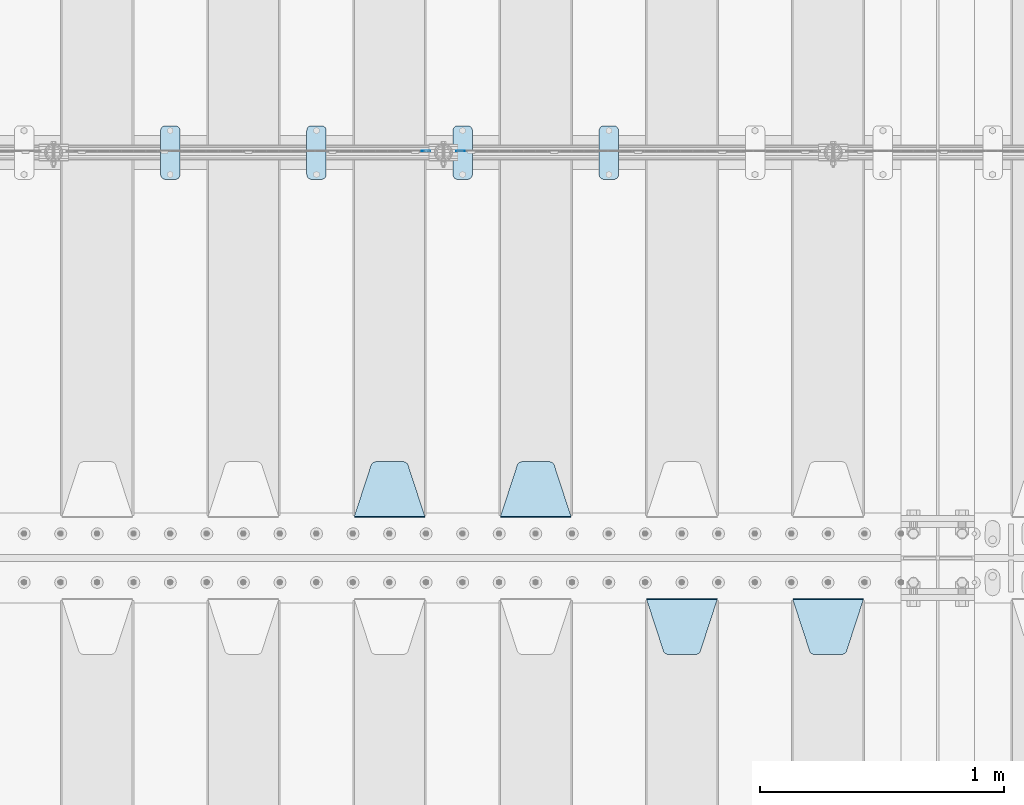
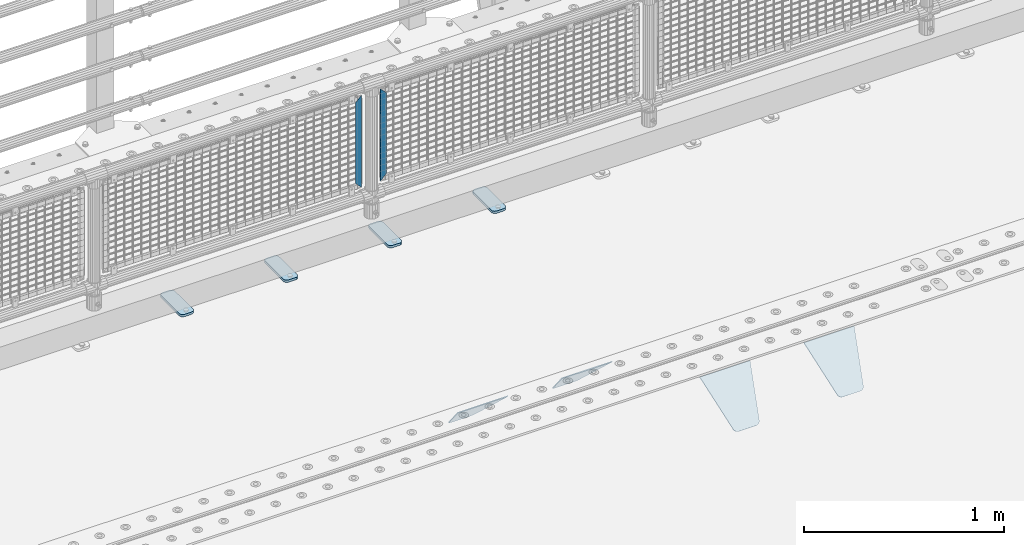
# One storey, part 226 of 257: 10 plates.
"""IFC2X3 building model written with IfcOpenShell, lengths in millimetres."""

from ifc_helpers import new_model, si_unit, frame, origin_with_axes, place, context, subcontext, project, spatial, faceted_brep, material, type_object, element, save


model = new_model("IFC2X3")

# Units and contexts
model_context = context("Model", 3, precision=1e-05, world=origin_with_axes())
body_context = subcontext(model_context, "Body", "Model", "MODEL_VIEW")
ifc_project = project(units=[si_unit("LENGTHUNIT", "METRE", prefix="MILLI"), si_unit("AREAUNIT", "SQUARE_METRE"), si_unit("VOLUMEUNIT", "CUBIC_METRE"), si_unit("MASSUNIT", "GRAM", prefix="KILO"), si_unit("TIMEUNIT", "SECOND"), si_unit("PLANEANGLEUNIT", "RADIAN"), si_unit("SOLIDANGLEUNIT", "STERADIAN"), si_unit("THERMODYNAMICTEMPERATUREUNIT", "DEGREE_CELSIUS"), si_unit("LUMINOUSINTENSITYUNIT", "LUMEN")], contexts=[model_context])

# Site, building, storey
site_placement = place(None, origin_with_axes())
site = spatial("IfcSite", under=ifc_project, at=site_placement, CompositionType="ELEMENT")
building_placement = place(site_placement, origin_with_axes())
building = spatial("IfcBuilding", under=site, at=building_placement, Name="Standard", CompositionType="ELEMENT")
storey_placement = place(building_placement, origin_with_axes())
storey = spatial("IfcBuildingStorey", under=building, at=storey_placement, Name="Undefined", CompositionType="ELEMENT", Elevation=0.0)

# Plates
ifc_material_1 = material(Name="STEEL/S355J2")
plate_type_1 = type_object("IfcPlateType", PredefinedType="NOTDEFINED")
plate_1_placement = place(storey_placement, frame((53310.0, 10774.5, 21.0199999999977), z_axis=(1.0, 0.0, 0.0), x_axis=(0.0, -1.0, 0.0)))
element("IfcPlate", 1, at=plate_1_placement, inside=storey, type_object=plate_type_1, material=ifc_material_1, context=body_context, shape_type="Brep", body=[
    faceted_brep([(0.0, -7.0, 20.0), (0.0, -7.0, 60.0), (0.0, 7.0, 60.0), (0.0, 7.0, 20.0), (0.384294391935327, -7.0, 63.9018064403208), (0.384294391935327, 7.0, 63.9018064403208), (1.52240934977453, -7.0, 67.6536686473046), (1.52240934977453, 7.0, 67.6536686473046), (3.37060775394821, -7.0, 71.1114046603907), (3.37060775394821, 7.0, 71.1114046603907), (5.85786437626848, -7.0, 74.1421356237333), (5.85786437626848, 7.0, 74.1421356237333), (8.88859533960749, -7.0, 76.6293922460536), (8.88859533960749, 7.0, 76.6293922460536), (12.3463313526991, -7.0, 78.4775906502255), (12.3463313526991, 7.0, 78.4775906502255), (16.0981935596774, -7.0, 79.6157056080629), (16.0981935596774, 7.0, 79.6157056080629), (20.0, -7.0, 80.0), (20.0, 7.0, 80.0), (200.0, -7.0, 80.0), (200.0, 7.0, 80.0), (203.901806440323, -7.0, 79.6157056080629), (203.901806440323, 7.0, 79.6157056080629), (207.653668647301, -7.0, 78.4775906502255), (207.653668647301, 7.0, 78.4775906502255), (211.111404660393, -7.0, 76.6293922460536), (211.111404660393, 7.0, 76.6293922460536), (214.142135623732, -7.0, 74.1421356237333), (214.142135623732, 7.0, 74.1421356237333), (216.629392246052, -7.0, 71.1114046603907), (216.629392246052, 7.0, 71.1114046603907), (218.477590650225, -7.0, 67.6536686473046), (218.477590650225, 7.0, 67.6536686473046), (219.615705608065, -7.0, 63.9018064403208), (219.615705608065, 7.0, 63.9018064403208), (220.0, -7.0, 60.0), (220.0, 7.0, 60.0), (220.0, -7.0, 20.0), (220.0, 7.0, 20.0), (219.615705608065, -7.0, 16.0981935596792), (219.615705608065, 7.0, 16.0981935596792), (218.477590650225, -7.0, 12.3463313526954), (218.477590650225, 7.0, 12.3463313526954), (216.629392246052, -7.0, 8.88859533960931), (216.629392246052, 7.0, 8.88859533960931), (214.142135623732, -7.0, 5.85786437626666), (214.142135623732, 7.0, 5.85786437626666), (211.111404660393, -7.0, 3.37060775394639), (211.111404660393, 7.0, 3.37060775394639), (207.653668647301, -7.0, 1.52240934977453), (207.653668647301, 7.0, 1.52240934977453), (203.901806440323, -7.0, 0.384294391937146), (203.901806440323, 7.0, 0.384294391937146), (200.0, -7.0, 0.0), (200.0, 7.0, 0.0), (20.0, -7.0, 0.0), (20.0, 7.0, 0.0), (16.0981935596774, -7.0, 0.384294391937146), (16.0981935596774, 7.0, 0.384294391937146), (12.3463313526991, -7.0, 1.52240934977453), (12.3463313526991, 7.0, 1.52240934977453), (8.88859533960749, -7.0, 3.37060775394639), (8.88859533960749, 7.0, 3.37060775394639), (5.85786437626848, -7.0, 5.85786437626666), (5.85786437626848, 7.0, 5.85786437626666), (3.37060775394821, -7.0, 8.88859533960931), (3.37060775394821, 7.0, 8.88859533960931), (1.52240934977453, -7.0, 12.3463313526954), (1.52240934977453, 7.0, 12.3463313526954), (0.384294391935327, -7.0, 16.0981935596792), (0.384294391935327, 7.0, 16.0981935596792)], [[[0, 1, 2, 3]], [[1, 4, 5, 2]], [[4, 6, 7, 5]], [[6, 8, 9, 7]], [[8, 10, 11, 9]], [[10, 12, 13, 11]], [[12, 14, 15, 13]], [[14, 16, 17, 15]], [[16, 18, 19, 17]], [[18, 20, 21, 19]], [[20, 22, 23, 21]], [[22, 24, 25, 23]], [[24, 26, 27, 25]], [[26, 28, 29, 27]], [[28, 30, 31, 29]], [[30, 32, 33, 31]], [[32, 34, 35, 33]], [[34, 36, 37, 35]], [[36, 38, 39, 37]], [[38, 40, 41, 39]], [[40, 42, 43, 41]], [[42, 44, 45, 43]], [[44, 46, 47, 45]], [[46, 48, 49, 47]], [[48, 50, 51, 49]], [[50, 52, 53, 51]], [[52, 54, 55, 53]], [[54, 56, 57, 55]], [[56, 58, 59, 57]], [[58, 60, 61, 59]], [[60, 62, 63, 61]], [[62, 64, 65, 63]], [[64, 66, 67, 65]], [[66, 68, 69, 67]], [[68, 70, 71, 69]], [[70, 0, 3, 71]], [[5, 7, 9, 11, 13, 15, 17, 19, 21, 23, 25, 27, 29, 31, 33, 35, 37, 39, 41, 43, 45, 47, 49, 51, 53, 55, 57, 59, 61, 63, 65, 67, 69, 71, 3, 2]], [[70, 68, 66, 64, 62, 60, 58, 56, 54, 52, 50, 48, 46, 44, 42, 40, 38, 36, 34, 32, 30, 28, 26, 24, 22, 20, 18, 16, 14, 12, 10, 8, 6, 4, 1, 0]]]),
])
plate_2_placement = place(storey_placement, frame((52710.0, 10774.5, 21.0199999999977), z_axis=(1.0, 0.0, 0.0), x_axis=(0.0, -1.0, 0.0)))
element("IfcPlate", 2, at=plate_2_placement, inside=storey, type_object=plate_type_1, material=ifc_material_1, context=body_context, shape_type="Brep", body=[
    faceted_brep([(0.0, -7.0, 20.0), (0.0, -7.0, 60.0), (0.0, 7.0, 60.0), (0.0, 7.0, 20.0), (0.384294391935327, -7.0, 63.9018064403208), (0.384294391935327, 7.0, 63.9018064403208), (1.52240934977453, -7.0, 67.6536686473046), (1.52240934977453, 7.0, 67.6536686473046), (3.37060775394821, -7.0, 71.1114046603907), (3.37060775394821, 7.0, 71.1114046603907), (5.85786437626848, -7.0, 74.1421356237333), (5.85786437626848, 7.0, 74.1421356237333), (8.88859533960749, -7.0, 76.6293922460536), (8.88859533960749, 7.0, 76.6293922460536), (12.3463313526991, -7.0, 78.4775906502255), (12.3463313526991, 7.0, 78.4775906502255), (16.0981935596774, -7.0, 79.6157056080629), (16.0981935596774, 7.0, 79.6157056080629), (20.0, -7.0, 80.0), (20.0, 7.0, 80.0), (200.0, -7.0, 80.0), (200.0, 7.0, 80.0), (203.901806440323, -7.0, 79.6157056080629), (203.901806440323, 7.0, 79.6157056080629), (207.653668647301, -7.0, 78.4775906502255), (207.653668647301, 7.0, 78.4775906502255), (211.111404660393, -7.0, 76.6293922460536), (211.111404660393, 7.0, 76.6293922460536), (214.142135623732, -7.0, 74.1421356237333), (214.142135623732, 7.0, 74.1421356237333), (216.629392246052, -7.0, 71.1114046603907), (216.629392246052, 7.0, 71.1114046603907), (218.477590650225, -7.0, 67.6536686473046), (218.477590650225, 7.0, 67.6536686473046), (219.615705608065, -7.0, 63.9018064403208), (219.615705608065, 7.0, 63.9018064403208), (220.0, -7.0, 60.0), (220.0, 7.0, 60.0), (220.0, -7.0, 20.0), (220.0, 7.0, 20.0), (219.615705608065, -7.0, 16.0981935596792), (219.615705608065, 7.0, 16.0981935596792), (218.477590650225, -7.0, 12.3463313526954), (218.477590650225, 7.0, 12.3463313526954), (216.629392246052, -7.0, 8.88859533960931), (216.629392246052, 7.0, 8.88859533960931), (214.142135623732, -7.0, 5.85786437626666), (214.142135623732, 7.0, 5.85786437626666), (211.111404660393, -7.0, 3.37060775394639), (211.111404660393, 7.0, 3.37060775394639), (207.653668647301, -7.0, 1.52240934977453), (207.653668647301, 7.0, 1.52240934977453), (203.901806440323, -7.0, 0.384294391937146), (203.901806440323, 7.0, 0.384294391937146), (200.0, -7.0, 0.0), (200.0, 7.0, 0.0), (20.0, -7.0, 0.0), (20.0, 7.0, 0.0), (16.0981935596774, -7.0, 0.384294391937146), (16.0981935596774, 7.0, 0.384294391937146), (12.3463313526991, -7.0, 1.52240934977453), (12.3463313526991, 7.0, 1.52240934977453), (8.88859533960749, -7.0, 3.37060775394639), (8.88859533960749, 7.0, 3.37060775394639), (5.85786437626848, -7.0, 5.85786437626666), (5.85786437626848, 7.0, 5.85786437626666), (3.37060775394821, -7.0, 8.88859533960931), (3.37060775394821, 7.0, 8.88859533960931), (1.52240934977453, -7.0, 12.3463313526954), (1.52240934977453, 7.0, 12.3463313526954), (0.384294391935327, -7.0, 16.0981935596792), (0.384294391935327, 7.0, 16.0981935596792)], [[[0, 1, 2, 3]], [[1, 4, 5, 2]], [[4, 6, 7, 5]], [[6, 8, 9, 7]], [[8, 10, 11, 9]], [[10, 12, 13, 11]], [[12, 14, 15, 13]], [[14, 16, 17, 15]], [[16, 18, 19, 17]], [[18, 20, 21, 19]], [[20, 22, 23, 21]], [[22, 24, 25, 23]], [[24, 26, 27, 25]], [[26, 28, 29, 27]], [[28, 30, 31, 29]], [[30, 32, 33, 31]], [[32, 34, 35, 33]], [[34, 36, 37, 35]], [[36, 38, 39, 37]], [[38, 40, 41, 39]], [[40, 42, 43, 41]], [[42, 44, 45, 43]], [[44, 46, 47, 45]], [[46, 48, 49, 47]], [[48, 50, 51, 49]], [[50, 52, 53, 51]], [[52, 54, 55, 53]], [[54, 56, 57, 55]], [[56, 58, 59, 57]], [[58, 60, 61, 59]], [[60, 62, 63, 61]], [[62, 64, 65, 63]], [[64, 66, 67, 65]], [[66, 68, 69, 67]], [[68, 70, 71, 69]], [[70, 0, 3, 71]], [[5, 7, 9, 11, 13, 15, 17, 19, 21, 23, 25, 27, 29, 31, 33, 35, 37, 39, 41, 43, 45, 47, 49, 51, 53, 55, 57, 59, 61, 63, 65, 67, 69, 71, 3, 2]], [[70, 68, 66, 64, 62, 60, 58, 56, 54, 52, 50, 48, 46, 44, 42, 40, 38, 36, 34, 32, 30, 28, 26, 24, 22, 20, 18, 16, 14, 12, 10, 8, 6, 4, 1, 0]]]),
])
plate_3_placement = place(storey_placement, frame((52110.0, 10774.5, 21.0199999999977), z_axis=(1.0, 0.0, 0.0), x_axis=(0.0, -1.0, 0.0)))
element("IfcPlate", 3, at=plate_3_placement, inside=storey, type_object=plate_type_1, material=ifc_material_1, context=body_context, shape_type="Brep", body=[
    faceted_brep([(0.0, -7.0, 20.0), (0.0, -7.0, 60.0), (0.0, 7.0, 60.0), (0.0, 7.0, 20.0), (0.384294391935327, -7.0, 63.9018064403208), (0.384294391935327, 7.0, 63.9018064403208), (1.52240934977453, -7.0, 67.6536686473046), (1.52240934977453, 7.0, 67.6536686473046), (3.37060775394821, -7.0, 71.1114046603907), (3.37060775394821, 7.0, 71.1114046603907), (5.85786437626848, -7.0, 74.1421356237333), (5.85786437626848, 7.0, 74.1421356237333), (8.88859533960749, -7.0, 76.6293922460536), (8.88859533960749, 7.0, 76.6293922460536), (12.3463313526991, -7.0, 78.4775906502255), (12.3463313526991, 7.0, 78.4775906502255), (16.0981935596774, -7.0, 79.6157056080629), (16.0981935596774, 7.0, 79.6157056080629), (20.0, -7.0, 80.0), (20.0, 7.0, 80.0), (200.0, -7.0, 80.0), (200.0, 7.0, 80.0), (203.901806440323, -7.0, 79.6157056080629), (203.901806440323, 7.0, 79.6157056080629), (207.653668647301, -7.0, 78.4775906502255), (207.653668647301, 7.0, 78.4775906502255), (211.111404660393, -7.0, 76.6293922460536), (211.111404660393, 7.0, 76.6293922460536), (214.142135623732, -7.0, 74.1421356237333), (214.142135623732, 7.0, 74.1421356237333), (216.629392246052, -7.0, 71.1114046603907), (216.629392246052, 7.0, 71.1114046603907), (218.477590650225, -7.0, 67.6536686473046), (218.477590650225, 7.0, 67.6536686473046), (219.615705608065, -7.0, 63.9018064403208), (219.615705608065, 7.0, 63.9018064403208), (220.0, -7.0, 60.0), (220.0, 7.0, 60.0), (220.0, -7.0, 20.0), (220.0, 7.0, 20.0), (219.615705608065, -7.0, 16.0981935596792), (219.615705608065, 7.0, 16.0981935596792), (218.477590650225, -7.0, 12.3463313526954), (218.477590650225, 7.0, 12.3463313526954), (216.629392246052, -7.0, 8.88859533960931), (216.629392246052, 7.0, 8.88859533960931), (214.142135623732, -7.0, 5.85786437626666), (214.142135623732, 7.0, 5.85786437626666), (211.111404660393, -7.0, 3.37060775394639), (211.111404660393, 7.0, 3.37060775394639), (207.653668647301, -7.0, 1.52240934977453), (207.653668647301, 7.0, 1.52240934977453), (203.901806440323, -7.0, 0.384294391937146), (203.901806440323, 7.0, 0.384294391937146), (200.0, -7.0, 0.0), (200.0, 7.0, 0.0), (20.0, -7.0, 0.0), (20.0, 7.0, 0.0), (16.0981935596774, -7.0, 0.384294391937146), (16.0981935596774, 7.0, 0.384294391937146), (12.3463313526991, -7.0, 1.52240934977453), (12.3463313526991, 7.0, 1.52240934977453), (8.88859533960749, -7.0, 3.37060775394639), (8.88859533960749, 7.0, 3.37060775394639), (5.85786437626848, -7.0, 5.85786437626666), (5.85786437626848, 7.0, 5.85786437626666), (3.37060775394821, -7.0, 8.88859533960931), (3.37060775394821, 7.0, 8.88859533960931), (1.52240934977453, -7.0, 12.3463313526954), (1.52240934977453, 7.0, 12.3463313526954), (0.384294391935327, -7.0, 16.0981935596792), (0.384294391935327, 7.0, 16.0981935596792)], [[[0, 1, 2, 3]], [[1, 4, 5, 2]], [[4, 6, 7, 5]], [[6, 8, 9, 7]], [[8, 10, 11, 9]], [[10, 12, 13, 11]], [[12, 14, 15, 13]], [[14, 16, 17, 15]], [[16, 18, 19, 17]], [[18, 20, 21, 19]], [[20, 22, 23, 21]], [[22, 24, 25, 23]], [[24, 26, 27, 25]], [[26, 28, 29, 27]], [[28, 30, 31, 29]], [[30, 32, 33, 31]], [[32, 34, 35, 33]], [[34, 36, 37, 35]], [[36, 38, 39, 37]], [[38, 40, 41, 39]], [[40, 42, 43, 41]], [[42, 44, 45, 43]], [[44, 46, 47, 45]], [[46, 48, 49, 47]], [[48, 50, 51, 49]], [[50, 52, 53, 51]], [[52, 54, 55, 53]], [[54, 56, 57, 55]], [[56, 58, 59, 57]], [[58, 60, 61, 59]], [[60, 62, 63, 61]], [[62, 64, 65, 63]], [[64, 66, 67, 65]], [[66, 68, 69, 67]], [[68, 70, 71, 69]], [[70, 0, 3, 71]], [[5, 7, 9, 11, 13, 15, 17, 19, 21, 23, 25, 27, 29, 31, 33, 35, 37, 39, 41, 43, 45, 47, 49, 51, 53, 55, 57, 59, 61, 63, 65, 67, 69, 71, 3, 2]], [[70, 68, 66, 64, 62, 60, 58, 56, 54, 52, 50, 48, 46, 44, 42, 40, 38, 36, 34, 32, 30, 28, 26, 24, 22, 20, 18, 16, 14, 12, 10, 8, 6, 4, 1, 0]]]),
])
plate_4_placement = place(storey_placement, frame((51510.0, 10774.5, 21.0199999999977), z_axis=(1.0, 0.0, 0.0), x_axis=(0.0, -1.0, 0.0)))
element("IfcPlate", 4, at=plate_4_placement, inside=storey, type_object=plate_type_1, material=ifc_material_1, context=body_context, shape_type="Brep", body=[
    faceted_brep([(0.0, -7.0, 20.0), (0.0, -7.0, 60.0), (0.0, 7.0, 60.0), (0.0, 7.0, 20.0), (0.384294391935327, -7.0, 63.9018064403208), (0.384294391935327, 7.0, 63.9018064403208), (1.52240934977453, -7.0, 67.6536686473046), (1.52240934977453, 7.0, 67.6536686473046), (3.37060775394821, -7.0, 71.1114046603907), (3.37060775394821, 7.0, 71.1114046603907), (5.85786437626848, -7.0, 74.1421356237333), (5.85786437626848, 7.0, 74.1421356237333), (8.88859533960749, -7.0, 76.6293922460536), (8.88859533960749, 7.0, 76.6293922460536), (12.3463313526991, -7.0, 78.4775906502255), (12.3463313526991, 7.0, 78.4775906502255), (16.0981935596774, -7.0, 79.6157056080629), (16.0981935596774, 7.0, 79.6157056080629), (20.0, -7.0, 80.0), (20.0, 7.0, 80.0), (200.0, -7.0, 80.0), (200.0, 7.0, 80.0), (203.901806440323, -7.0, 79.6157056080629), (203.901806440323, 7.0, 79.6157056080629), (207.653668647301, -7.0, 78.4775906502255), (207.653668647301, 7.0, 78.4775906502255), (211.111404660393, -7.0, 76.6293922460536), (211.111404660393, 7.0, 76.6293922460536), (214.142135623732, -7.0, 74.1421356237333), (214.142135623732, 7.0, 74.1421356237333), (216.629392246052, -7.0, 71.1114046603907), (216.629392246052, 7.0, 71.1114046603907), (218.477590650225, -7.0, 67.6536686473046), (218.477590650225, 7.0, 67.6536686473046), (219.615705608065, -7.0, 63.9018064403208), (219.615705608065, 7.0, 63.9018064403208), (220.0, -7.0, 60.0), (220.0, 7.0, 60.0), (220.0, -7.0, 20.0), (220.0, 7.0, 20.0), (219.615705608065, -7.0, 16.0981935596792), (219.615705608065, 7.0, 16.0981935596792), (218.477590650225, -7.0, 12.3463313526954), (218.477590650225, 7.0, 12.3463313526954), (216.629392246052, -7.0, 8.88859533960931), (216.629392246052, 7.0, 8.88859533960931), (214.142135623732, -7.0, 5.85786437626666), (214.142135623732, 7.0, 5.85786437626666), (211.111404660393, -7.0, 3.37060775394639), (211.111404660393, 7.0, 3.37060775394639), (207.653668647301, -7.0, 1.52240934977453), (207.653668647301, 7.0, 1.52240934977453), (203.901806440323, -7.0, 0.384294391937146), (203.901806440323, 7.0, 0.384294391937146), (200.0, -7.0, 0.0), (200.0, 7.0, 0.0), (20.0, -7.0, 0.0), (20.0, 7.0, 0.0), (16.0981935596774, -7.0, 0.384294391937146), (16.0981935596774, 7.0, 0.384294391937146), (12.3463313526991, -7.0, 1.52240934977453), (12.3463313526991, 7.0, 1.52240934977453), (8.88859533960749, -7.0, 3.37060775394639), (8.88859533960749, 7.0, 3.37060775394639), (5.85786437626848, -7.0, 5.85786437626666), (5.85786437626848, 7.0, 5.85786437626666), (3.37060775394821, -7.0, 8.88859533960931), (3.37060775394821, 7.0, 8.88859533960931), (1.52240934977453, -7.0, 12.3463313526954), (1.52240934977453, 7.0, 12.3463313526954), (0.384294391935327, -7.0, 16.0981935596792), (0.384294391935327, 7.0, 16.0981935596792)], [[[0, 1, 2, 3]], [[1, 4, 5, 2]], [[4, 6, 7, 5]], [[6, 8, 9, 7]], [[8, 10, 11, 9]], [[10, 12, 13, 11]], [[12, 14, 15, 13]], [[14, 16, 17, 15]], [[16, 18, 19, 17]], [[18, 20, 21, 19]], [[20, 22, 23, 21]], [[22, 24, 25, 23]], [[24, 26, 27, 25]], [[26, 28, 29, 27]], [[28, 30, 31, 29]], [[30, 32, 33, 31]], [[32, 34, 35, 33]], [[34, 36, 37, 35]], [[36, 38, 39, 37]], [[38, 40, 41, 39]], [[40, 42, 43, 41]], [[42, 44, 45, 43]], [[44, 46, 47, 45]], [[46, 48, 49, 47]], [[48, 50, 51, 49]], [[50, 52, 53, 51]], [[52, 54, 55, 53]], [[54, 56, 57, 55]], [[56, 58, 59, 57]], [[58, 60, 61, 59]], [[60, 62, 63, 61]], [[62, 64, 65, 63]], [[64, 66, 67, 65]], [[66, 68, 69, 67]], [[68, 70, 71, 69]], [[70, 0, 3, 71]], [[5, 7, 9, 11, 13, 15, 17, 19, 21, 23, 25, 27, 29, 31, 33, 35, 37, 39, 41, 43, 45, 47, 49, 51, 53, 55, 57, 59, 61, 63, 65, 67, 69, 71, 3, 2]], [[70, 68, 66, 64, 62, 60, 58, 56, 54, 52, 50, 48, 46, 44, 42, 40, 38, 36, 34, 32, 30, 28, 26, 24, 22, 20, 18, 16, 14, 12, 10, 8, 6, 4, 1, 0]]]),
])
ifc_material_2 = material(Name="STEEL/S355N")
plate_type_2 = type_object("IfcPlateType", PredefinedType="NOTDEFINED")
plate_5_placement = place(storey_placement, frame((54105.0, 8831.76776695594, -1.767766952965), z_axis=(0.0, -0.707106781186548, -0.707106781186547), x_axis=(1.0, 0.0, 0.0)))
element("IfcPlate", 5, at=plate_5_placement, inside=storey, type_object=plate_type_2, material=ifc_material_2, context=body_context, shape_type="Brep", body=[
    faceted_brep([(0.0, -2.5, 0.0), (69.345504679477, -2.50000000000091, 300.17173142483), (69.345504679477, 2.5, 300.171731424831), (0.0, 2.5, 0.0), (70.927406119954, -2.50000000000091, 304.8974424154), (70.927406119954, 2.5, 304.8974424154), (73.3818627772271, -2.50000000000091, 309.234538108527), (73.3818627772271, 2.49999999999909, 309.234538108527), (76.6187032999587, -2.5, 313.023683126103), (76.6187032999587, 2.5, 313.023683126103), (80.5190132705029, -2.5, 316.125672595372), (80.5190132705029, 2.5, 316.125672595371), (84.9395038596849, -2.5, 318.426546230476), (84.9395038596849, 2.5, 318.426546230477), (89.7177759439219, -2.5, 319.841774983275), (89.7177759439219, 2.5, 319.841774983275), (94.6782862926484, -2.5, 320.319366455079), (94.6782862926484, 2.5, 320.319366455079), (195.321713707352, -2.5, 320.319366455079), (195.321713707352, 2.5, 320.319366455079), (200.282224056078, -2.5, 319.841774983275), (200.282224056078, 2.49999999999909, 319.841774983275), (205.060496140315, -2.5, 318.426546230476), (205.060496140315, 2.49999999999909, 318.426546230475), (209.480986729497, -2.5, 316.125672595371), (209.480986729497, 2.5, 316.125672595371), (213.381296700041, -2.50000000000091, 313.023683126102), (213.381296700041, 2.5, 313.023683126103), (216.618137222766, -2.50000000000091, 309.234538108527), (216.618137222766, 2.5, 309.234538108527), (219.072593880039, -2.5, 304.897442415399), (219.072593880039, 2.5, 304.897442415399), (220.654495320523, -2.50000000000091, 300.17173142483), (220.654495320523, 2.5, 300.171731424831), (290.0, -2.50000000000091, 0.0), (290.0, 2.5, 9.09494701772928e-13)], [[[0, 1, 2, 3]], [[1, 4, 5, 2]], [[4, 6, 7, 5]], [[6, 8, 9, 7]], [[8, 10, 11, 9]], [[10, 12, 13, 11]], [[12, 14, 15, 13]], [[14, 16, 17, 15]], [[16, 18, 19, 17]], [[18, 20, 21, 19]], [[20, 22, 23, 21]], [[22, 24, 25, 23]], [[24, 26, 27, 25]], [[26, 28, 29, 27]], [[28, 30, 31, 29]], [[30, 32, 33, 31]], [[32, 34, 35, 33]], [[34, 0, 3, 35]], [[5, 7, 9, 11, 13, 15, 17, 19, 21, 23, 25, 27, 29, 31, 33, 35, 3, 2]], [[34, 32, 30, 28, 26, 24, 22, 20, 18, 16, 14, 12, 10, 8, 6, 4, 1, 0]]]),
])
plate_6_placement = place(storey_placement, frame((53505.0, 8831.76776695594, -1.767766952965), z_axis=(0.0, -0.707106781186548, -0.707106781186547), x_axis=(1.0, 0.0, 0.0)))
element("IfcPlate", 6, at=plate_6_placement, inside=storey, type_object=plate_type_2, material=ifc_material_2, context=body_context, shape_type="Brep", body=[
    faceted_brep([(0.0, -2.5, 0.0), (69.345504679477, -2.50000000000091, 300.17173142483), (69.345504679477, 2.5, 300.171731424831), (0.0, 2.5, 0.0), (70.927406119954, -2.50000000000091, 304.8974424154), (70.927406119954, 2.5, 304.8974424154), (73.3818627772271, -2.50000000000091, 309.234538108527), (73.3818627772271, 2.49999999999909, 309.234538108527), (76.6187032999587, -2.5, 313.023683126103), (76.6187032999587, 2.5, 313.023683126103), (80.5190132705029, -2.5, 316.125672595372), (80.5190132705029, 2.5, 316.125672595371), (84.9395038596849, -2.5, 318.426546230476), (84.9395038596849, 2.5, 318.426546230477), (89.7177759439219, -2.5, 319.841774983275), (89.7177759439219, 2.5, 319.841774983275), (94.6782862926484, -2.5, 320.319366455079), (94.6782862926484, 2.5, 320.319366455079), (195.321713707352, -2.5, 320.319366455079), (195.321713707352, 2.5, 320.319366455079), (200.282224056078, -2.5, 319.841774983275), (200.282224056078, 2.49999999999909, 319.841774983275), (205.060496140315, -2.5, 318.426546230476), (205.060496140315, 2.49999999999909, 318.426546230475), (209.480986729497, -2.5, 316.125672595371), (209.480986729497, 2.5, 316.125672595371), (213.381296700041, -2.50000000000091, 313.023683126102), (213.381296700041, 2.5, 313.023683126103), (216.618137222766, -2.50000000000091, 309.234538108527), (216.618137222766, 2.5, 309.234538108527), (219.072593880039, -2.5, 304.897442415399), (219.072593880039, 2.5, 304.897442415399), (220.654495320523, -2.50000000000091, 300.17173142483), (220.654495320523, 2.5, 300.171731424831), (290.0, -2.50000000000091, 0.0), (290.0, 2.5, 9.09494701772928e-13)], [[[0, 1, 2, 3]], [[1, 4, 5, 2]], [[4, 6, 7, 5]], [[6, 8, 9, 7]], [[8, 10, 11, 9]], [[10, 12, 13, 11]], [[12, 14, 15, 13]], [[14, 16, 17, 15]], [[16, 18, 19, 17]], [[18, 20, 21, 19]], [[20, 22, 23, 21]], [[22, 24, 25, 23]], [[24, 26, 27, 25]], [[26, 28, 29, 27]], [[28, 30, 31, 29]], [[30, 32, 33, 31]], [[32, 34, 35, 33]], [[34, 0, 3, 35]], [[5, 7, 9, 11, 13, 15, 17, 19, 21, 23, 25, 27, 29, 31, 33, 35, 3, 2]], [[34, 32, 30, 28, 26, 24, 22, 20, 18, 16, 14, 12, 10, 8, 6, 4, 1, 0]]]),
])
plate_7_placement = place(storey_placement, frame((53195.0, 9168.23223304703, -1.76776695296758), z_axis=(0.0, 0.707106781186547, -0.707106781186548), x_axis=(-1.0, 0.0, 0.0)))
element("IfcPlate", 7, at=plate_7_placement, inside=storey, type_object=plate_type_2, material=ifc_material_2, context=body_context, shape_type="Brep", body=[
    faceted_brep([(0.0, -2.5, 0.0), (69.345504679477, -2.50000000000091, 300.17173142483), (69.345504679477, 2.5, 300.171731424831), (0.0, 2.5, 0.0), (70.927406119954, -2.50000000000091, 304.8974424154), (70.927406119954, 2.5, 304.8974424154), (73.3818627772271, -2.50000000000091, 309.234538108527), (73.3818627772271, 2.49999999999909, 309.234538108527), (76.6187032999587, -2.5, 313.023683126103), (76.6187032999587, 2.5, 313.023683126103), (80.5190132705029, -2.5, 316.125672595372), (80.5190132705029, 2.5, 316.125672595371), (84.9395038596849, -2.5, 318.426546230476), (84.9395038596849, 2.5, 318.426546230477), (89.7177759439219, -2.5, 319.841774983275), (89.7177759439219, 2.5, 319.841774983275), (94.6782862926484, -2.5, 320.319366455079), (94.6782862926484, 2.5, 320.319366455079), (195.321713707352, -2.5, 320.319366455079), (195.321713707352, 2.5, 320.319366455079), (200.282224056078, -2.5, 319.841774983275), (200.282224056078, 2.49999999999909, 319.841774983275), (205.060496140315, -2.5, 318.426546230476), (205.060496140315, 2.49999999999909, 318.426546230475), (209.480986729497, -2.5, 316.125672595371), (209.480986729497, 2.5, 316.125672595371), (213.381296700041, -2.50000000000091, 313.023683126102), (213.381296700041, 2.5, 313.023683126103), (216.618137222766, -2.50000000000091, 309.234538108527), (216.618137222766, 2.5, 309.234538108527), (219.072593880039, -2.5, 304.897442415399), (219.072593880039, 2.5, 304.897442415399), (220.654495320523, -2.50000000000091, 300.17173142483), (220.654495320523, 2.5, 300.171731424831), (290.0, -2.50000000000091, 0.0), (290.0, 2.5, 9.09494701772928e-13)], [[[0, 1, 2, 3]], [[1, 4, 5, 2]], [[4, 6, 7, 5]], [[6, 8, 9, 7]], [[8, 10, 11, 9]], [[10, 12, 13, 11]], [[12, 14, 15, 13]], [[14, 16, 17, 15]], [[16, 18, 19, 17]], [[18, 20, 21, 19]], [[20, 22, 23, 21]], [[22, 24, 25, 23]], [[24, 26, 27, 25]], [[26, 28, 29, 27]], [[28, 30, 31, 29]], [[30, 32, 33, 31]], [[32, 34, 35, 33]], [[34, 0, 3, 35]], [[5, 7, 9, 11, 13, 15, 17, 19, 21, 23, 25, 27, 29, 31, 33, 35, 3, 2]], [[34, 32, 30, 28, 26, 24, 22, 20, 18, 16, 14, 12, 10, 8, 6, 4, 1, 0]]]),
])
plate_8_placement = place(storey_placement, frame((52595.0, 9168.23223304703, -1.76776695296758), z_axis=(0.0, 0.707106781186547, -0.707106781186548), x_axis=(-1.0, 0.0, 0.0)))
element("IfcPlate", 8, at=plate_8_placement, inside=storey, type_object=plate_type_2, material=ifc_material_2, context=body_context, shape_type="Brep", body=[
    faceted_brep([(0.0, -2.5, 0.0), (69.345504679477, -2.50000000000091, 300.17173142483), (69.345504679477, 2.5, 300.171731424831), (0.0, 2.5, 0.0), (70.927406119954, -2.50000000000091, 304.8974424154), (70.927406119954, 2.5, 304.8974424154), (73.3818627772271, -2.50000000000091, 309.234538108527), (73.3818627772271, 2.49999999999909, 309.234538108527), (76.6187032999587, -2.5, 313.023683126103), (76.6187032999587, 2.5, 313.023683126103), (80.5190132705029, -2.5, 316.125672595372), (80.5190132705029, 2.5, 316.125672595371), (84.9395038596849, -2.5, 318.426546230476), (84.9395038596849, 2.5, 318.426546230477), (89.7177759439219, -2.5, 319.841774983275), (89.7177759439219, 2.5, 319.841774983275), (94.6782862926484, -2.5, 320.319366455079), (94.6782862926484, 2.5, 320.319366455079), (195.321713707352, -2.5, 320.319366455079), (195.321713707352, 2.5, 320.319366455079), (200.282224056078, -2.5, 319.841774983275), (200.282224056078, 2.49999999999909, 319.841774983275), (205.060496140315, -2.5, 318.426546230476), (205.060496140315, 2.49999999999909, 318.426546230475), (209.480986729497, -2.5, 316.125672595371), (209.480986729497, 2.5, 316.125672595371), (213.381296700041, -2.50000000000091, 313.023683126102), (213.381296700041, 2.5, 313.023683126103), (216.618137222766, -2.50000000000091, 309.234538108527), (216.618137222766, 2.5, 309.234538108527), (219.072593880039, -2.5, 304.897442415399), (219.072593880039, 2.5, 304.897442415399), (220.654495320523, -2.50000000000091, 300.17173142483), (220.654495320523, 2.5, 300.171731424831), (290.0, -2.50000000000091, 0.0), (290.0, 2.5, 9.09494701772928e-13)], [[[0, 1, 2, 3]], [[1, 4, 5, 2]], [[4, 6, 7, 5]], [[6, 8, 9, 7]], [[8, 10, 11, 9]], [[10, 12, 13, 11]], [[12, 14, 15, 13]], [[14, 16, 17, 15]], [[16, 18, 19, 17]], [[18, 20, 21, 19]], [[20, 22, 23, 21]], [[22, 24, 25, 23]], [[24, 26, 27, 25]], [[26, 28, 29, 27]], [[28, 30, 31, 29]], [[30, 32, 33, 31]], [[32, 34, 35, 33]], [[34, 0, 3, 35]], [[5, 7, 9, 11, 13, 15, 17, 19, 21, 23, 25, 27, 29, 31, 33, 35, 3, 2]], [[34, 32, 30, 28, 26, 24, 22, 20, 18, 16, 14, 12, 10, 8, 6, 4, 1, 0]]]),
])
ifc_material_3 = material(Name="Misc_Undefined")
plate_type_3 = type_object("IfcPlateType", PredefinedType="NOTDEFINED")
plate_9_placement = place(storey_placement, frame((52759.509713541, 10670.5, 879.519963133601), z_axis=(-0.707008801899317, 0.0, -0.707204746899292), x_axis=(-0.707204746899293, 0.0, 0.707008801899317)))
element("IfcPlate", 9, at=plate_9_placement, inside=storey, type_object=plate_type_3, material=ifc_material_3, context=body_context, shape_type="Brep", body=[
    faceted_brep([(0.0, -1.5, -5.6843418860808e-14), (-348.552185058586, -1.5, 348.655029296868), (-348.552185058586, 1.5, 348.655029296868), (0.0, 1.5, -5.6843418860808e-14), (-348.544891357407, -1.5, 398.152496337891), (-348.544891357407, 1.5, 398.152496337891), (49.5043945312573, -1.5, 7.27595761418343e-11), (49.5043945312573, 1.5, 7.27595761418343e-11)], [[[0, 1, 2, 3]], [[1, 4, 5, 2]], [[4, 6, 7, 5]], [[6, 0, 3, 7]], [[5, 7, 3, 2]], [[6, 4, 1, 0]]]),
])
plate_10_placement = place(storey_placement, frame((52582.4996874836, 10670.5, 879.52), z_axis=(0.707103624179501, 0.0, -0.707109938179499), x_axis=(0.707109938179525, 0.0, 0.707103624179475)))
element("IfcPlate", 10, at=plate_10_placement, inside=storey, type_object=plate_type_3, material=ifc_material_3, context=body_context, shape_type="Brep", body=[
    faceted_brep([(0.0, -1.5, -5.6843418860808e-14), (-348.605163574226, -1.5, 348.602081298828), (-348.605163574226, 1.5, 348.602081298828), (0.0, 1.5, -5.6843418860808e-14), (-348.605163574226, -1.5, 398.099334716804), (-348.605163574226, 1.5, 398.099334716804), (49.4976959228443, -1.5, 6.54836185276508e-11), (49.4976959228443, 1.5, 6.54836185276508e-11)], [[[0, 1, 2, 3]], [[1, 4, 5, 2]], [[4, 6, 7, 5]], [[6, 0, 3, 7]], [[5, 7, 3, 2]], [[6, 4, 1, 0]]]),
])

save(model, "model.ifc")
